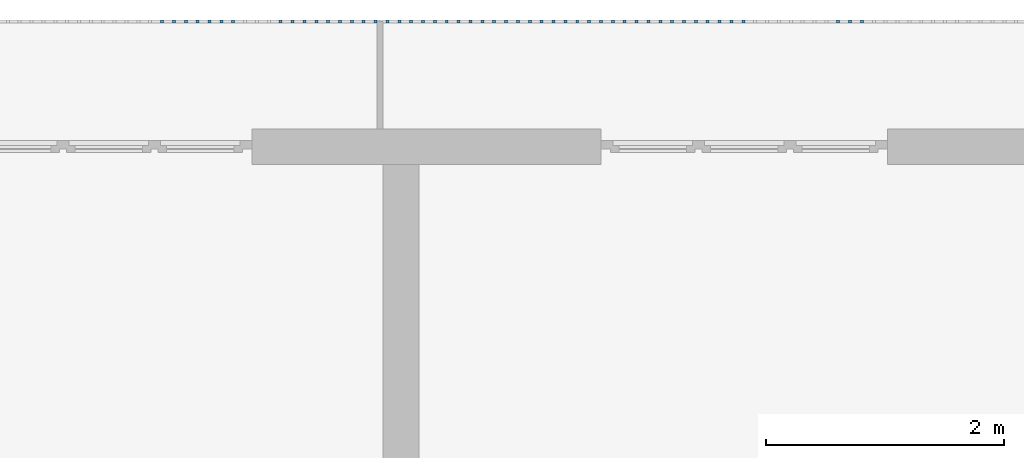
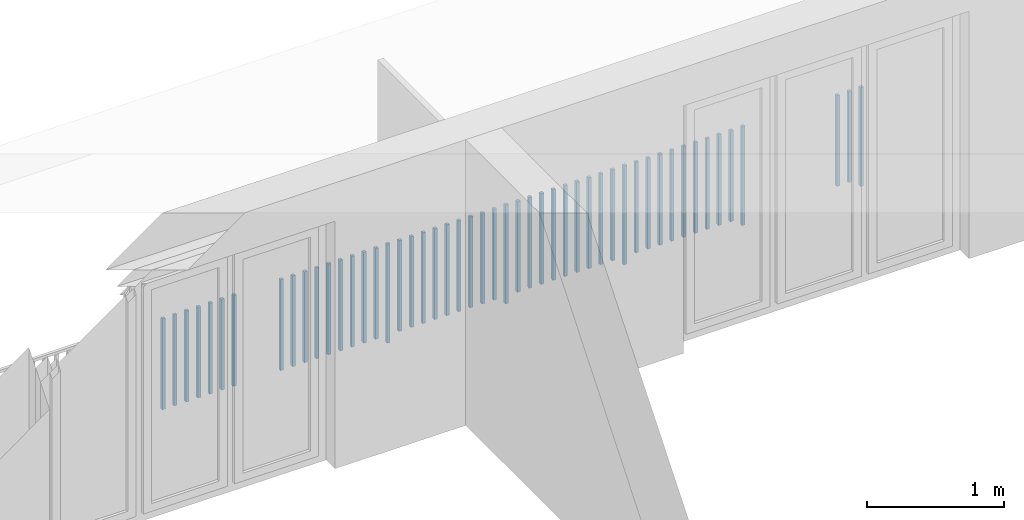
# One storey, part 44 of 48: 50 building element parts, 1 element without a shape of its own.
"""IFC4 building model written with IfcOpenShell, lengths in metres."""

import ifcopenshell
import ifcopenshell.guid

model = None  # the IFC model being written
_history = None  # IfcOwnerHistory: only IFC2X3 demands one
_inside = {}  # id of a spatial element -> (the spatial element, [elements in it])
_under = {}  # id of a project, library or spatial element -> (it, [spatial elements below it])
_declared = {}  # id of a project -> (the project, [libraries it declares])
_typed = {}  # id of a type object -> (the type object, [elements of that type])
_made_of = {}  # id of a material, layer set ... -> (it, [elements and type objects made of it])


def new_model(schema):
    """Start an empty IFC model of exactly this schema.

    Asked for "IFC4X3", IfcOpenShell would pick the latest addendum, in which some entities
    have other attributes; the version numbers below select the first issue.
    IFC2X3 requires an IfcOwnerHistory on every rooted entity: one is made here for all.
    """
    global model, _history
    if schema == "IFC4X3":
        model = ifcopenshell.file(schema_version=(4, 3, 0, 0))
    else:
        model = ifcopenshell.file(schema=schema)
    _inside.clear()
    _under.clear()
    _declared.clear()
    _typed.clear()
    _made_of.clear()
    _history = None
    if model.schema == "IFC2X3":
        org = make("IfcOrganization", Name="unknown")
        user = make(
            "IfcPersonAndOrganization",
            ThePerson=make("IfcPerson", FamilyName="unknown"),
            TheOrganization=org,
        )
        app = make(
            "IfcApplication",
            ApplicationDeveloper=org,
            Version="unknown",
            ApplicationFullName="unknown",
            ApplicationIdentifier="unknown",
        )
        _history = make(
            "IfcOwnerHistory",
            OwningUser=user,
            OwningApplication=app,
            ChangeAction="ADDED",
            CreationDate=0,
        )
    return model


def make(cls, **values):
    """One entity of the class cls with the attributes given. An attribute that is None is left unset."""
    return model.create_entity(
        cls, **{name: value for name, value in values.items() if value is not None}
    )


def entity(cls, *values):
    """Any entity or typed value of the class cls, its attributes in the order of the schema. None: left unset."""
    e = model.create_entity(cls)
    for i, value in enumerate(values):
        if value is not None:
            e[i] = value
    return e


def rooted(cls, **values):
    """An entity with a GlobalId (a new one), such as an element, a storey or a relation."""
    return make(cls, GlobalId=ifcopenshell.guid.new(), OwnerHistory=_history, **values)


def si_unit(unit_type, name, prefix=None):
    """IfcSIUnit, for example si_unit("LENGTHUNIT", "METRE", prefix="MILLI")."""
    return make("IfcSIUnit", UnitType=unit_type, Prefix=prefix, Name=name)


def converted_unit(unit_type, name, factor, base, dimensions=None, offset=None):
    """IfcConversionBasedUnit, such as the inch: factor (a typed value) times the base unit."""
    return make(
        "IfcConversionBasedUnit"
        if offset is None
        else "IfcConversionBasedUnitWithOffset",
        ConversionOffset=offset,
        Dimensions=None
        if dimensions is None
        else entity("IfcDimensionalExponents", *dimensions),
        UnitType=unit_type,
        Name=name,
        ConversionFactor=make(
            "IfcMeasureWithUnit", ValueComponent=factor, UnitComponent=base
        ),
    )


def derived_unit(unit_type, elements):
    """IfcDerivedUnit: a product of units, each with its exponent."""
    return make(
        "IfcDerivedUnit",
        Elements=[
            make("IfcDerivedUnitElement", Unit=unit, Exponent=power)
            for unit, power in elements
        ],
        UnitType=unit_type,
    )


def assignment(units):
    """IfcUnitAssignment: the units of a project."""
    return None if units is None else make("IfcUnitAssignment", Units=units)


def point(xyz):
    """IfcCartesianPoint."""
    return None if xyz is None else make("IfcCartesianPoint", Coordinates=xyz)


def direction(xyz):
    """IfcDirection."""
    return None if xyz is None else make("IfcDirection", DirectionRatios=xyz)


def frame(location, z_axis=None, x_axis=None):
    """IfcAxis2Placement3D, a coordinate frame: its origin and axes. An axis left out is left unset."""
    return make(
        "IfcAxis2Placement3D",
        Location=point(location),
        Axis=direction(z_axis),
        RefDirection=direction(x_axis),
    )


def origin_with_axes():
    """The frame at (0, 0, 0) with the z axis (0, 0, 1) and the x axis (1, 0, 0) written out."""
    return frame((0.0, 0.0, 0.0), z_axis=(0.0, 0.0, 1.0), x_axis=(1.0, 0.0, 0.0))


def place(relative_to, where):
    """IfcLocalPlacement: puts the frame where relative to a parent placement (None: the world)."""
    return make(
        "IfcLocalPlacement", PlacementRelTo=relative_to, RelativePlacement=where
    )


def context(
    kind, dimensions, precision=None, world=None, true_north=None, identifier=None
):
    """IfcGeometricRepresentationContext, for example the 3D "Model" context."""
    return make(
        "IfcGeometricRepresentationContext",
        ContextIdentifier=identifier,
        ContextType=kind,
        CoordinateSpaceDimension=dimensions,
        Precision=precision,
        WorldCoordinateSystem=world,
        TrueNorth=true_north,
    )


def subcontext(parent, identifier, kind, view, scale=None):
    """IfcGeometricRepresentationSubContext, for example "Body" below "Model"."""
    return make(
        "IfcGeometricRepresentationSubContext",
        ContextIdentifier=identifier,
        ContextType=kind,
        ParentContext=parent,
        TargetScale=scale,
        TargetView=view,
    )


def project(units=None, contexts=None):
    """IfcProject with its units and contexts."""
    return rooted(
        "IfcProject",
        Name="project",
        RepresentationContexts=contexts,
        UnitsInContext=assignment(units),
    )


def spatial(cls, under=None, at=None, **own):
    """A site, building, storey or space (cls), placed at a placement, below another one or the project."""
    s = rooted(cls, ObjectPlacement=at, **own)
    if under is not None:
        _under.setdefault(under.id(), (under, []))[1].append(s)
    return s


def point_list(points):
    """IfcCartesianPointList2D or 3D."""
    cls = (
        "IfcCartesianPointList2D" if len(points[0]) == 2 else "IfcCartesianPointList3D"
    )
    return make(cls, CoordList=points)


def polygons(points, faces, closed=None, point_numbers=None):
    """IfcPolygonalFaceSet: a face is its outer loop, then its inner loops; points numbered from 1."""
    made = []
    for loops in faces:
        if len(loops) == 1:
            made.append(make("IfcIndexedPolygonalFace", CoordIndex=loops[0]))
        else:
            made.append(
                make(
                    "IfcIndexedPolygonalFaceWithVoids",
                    CoordIndex=loops[0],
                    InnerCoordIndices=loops[1:],
                )
            )
    return make(
        "IfcPolygonalFaceSet",
        Coordinates=point_list(points),
        Closed=closed,
        Faces=made,
        PnIndex=point_numbers,
    )


def shape(context_of_items, identifier, shape_type, items):
    """IfcShapeRepresentation: the items that make up one representation, for example the "Body"."""
    return make(
        "IfcShapeRepresentation",
        ContextOfItems=context_of_items,
        RepresentationIdentifier=identifier,
        RepresentationType=shape_type,
        Items=items,
    )


def material(Name=None, Category=None):
    """IfcMaterial."""
    return make("IfcMaterial", Name=Name, Category=Category)


def made_of(thing, what):
    """Note that an element or type object is made of a material, layer set ...; save() writes the relation."""
    if what is not None:
        _made_of.setdefault(what.id(), (what, []))[1].append(thing)
    return thing


def type_object(cls, material=None, **own):
    """A type object (cls), such as IfcWallType, which elements share."""
    return made_of(rooted(cls, **own), material)


def element(
    cls,
    number,
    at=None,
    inside=None,
    cuts=None,
    type_object=None,
    material=None,
    context=None,
    identifier="Body",
    shape_type=None,
    held_by="IfcProductDefinitionShape",
    body=None,
    shapes=None,
    **own,
):
    """One element of the class cls, such as IfcWall. Its Tag is "e" and its number.

    at: its placement. inside: the storey or other place that contains it. cuts: it is an
    opening in that element (IfcRelVoidsElement). A single representation is given by context,
    identifier, shape_type and body (its items); several are given by shapes. held_by: the class
    of the entity that holds the representations. save() writes the other relations.
    """
    e = rooted(cls, Tag="e%d" % number, ObjectPlacement=at, **own)
    if body is not None:
        shapes = [shape(context, identifier, shape_type, body)]
    if shapes is not None:
        e.Representation = make(held_by, Representations=shapes)
    if inside is not None:
        _inside.setdefault(inside.id(), (inside, []))[1].append(e)
    if cuts is not None:
        rooted(
            "IfcRelVoidsElement", RelatingBuildingElement=cuts, RelatedOpeningElement=e
        )
    if type_object is not None:
        _typed.setdefault(type_object.id(), (type_object, []))[1].append(e)
    return made_of(e, material)


def aggregate(whole, parts):
    """IfcRelAggregates: a whole, such as a stair, and the parts it consists of."""
    return rooted("IfcRelAggregates", RelatingObject=whole, RelatedObjects=parts)


def save(model, path):
    """Write the relations noted so far, then the file.

    IfcRelAggregates (storeys below a building ...), IfcRelContainedInSpatialStructure (elements
    in a storey), IfcRelDefinesByType, IfcRelAssociatesMaterial and IfcRelDeclares: one each for
    every whole, place, type object, material and project.
    """
    for whole, parts in _under.values():
        aggregate(whole, parts)
    for where, things in _inside.values():
        rooted(
            "IfcRelContainedInSpatialStructure",
            RelatedElements=things,
            RelatingStructure=where,
        )
    for kind, things in _typed.values():
        rooted("IfcRelDefinesByType", RelatedObjects=things, RelatingType=kind)
    for what, things in _made_of.values():
        rooted("IfcRelAssociatesMaterial", RelatedObjects=things, RelatingMaterial=what)
    for by, libraries in _declared.values():
        rooted("IfcRelDeclares", RelatingContext=by, RelatedDefinitions=libraries)
    model.write(path)


model = new_model("IFC4")

# Units and contexts
model_context = context("Model", 3, precision=1e-05, world=origin_with_axes(), true_north=direction((0.0, 1.0)))
body_context = subcontext(model_context, "Body", "Model", "MODEL_VIEW")
ifc_project = project(units=[si_unit("LENGTHUNIT", "METRE"), si_unit("AREAUNIT", "SQUARE_METRE"), si_unit("VOLUMEUNIT", "CUBIC_METRE"), converted_unit("PLANEANGLEUNIT", "DEGREE", entity("IfcPlaneAngleMeasure", 0.0174532925199), si_unit("PLANEANGLEUNIT", "RADIAN"), dimensions=[0, 0, 0, 0, 0, 0, 0]), converted_unit("TIMEUNIT", "Year", entity("IfcTimeMeasure", 31556926.0), si_unit("TIMEUNIT", "SECOND"), dimensions=[0, 0, 1, 0, 0, 0, 0]), si_unit("MASSUNIT", "GRAM", prefix="KILO"), si_unit("THERMODYNAMICTEMPERATUREUNIT", "DEGREE_CELSIUS"), si_unit("LUMINOUSINTENSITYUNIT", "LUMEN"), si_unit("ENERGYUNIT", "JOULE", prefix="MEGA"), derived_unit("THERMALCONDUCTANCEUNIT", [(si_unit("POWERUNIT", "WATT"), 1), (si_unit("LENGTHUNIT", "METRE"), -1), (si_unit("THERMODYNAMICTEMPERATUREUNIT", "KELVIN"), -1)]), derived_unit("SPECIFICHEATCAPACITYUNIT", [(si_unit("ENERGYUNIT", "JOULE"), 1), (si_unit("MASSUNIT", "GRAM", prefix="KILO"), -1), (si_unit("THERMODYNAMICTEMPERATUREUNIT", "KELVIN"), -1)]), derived_unit("MASSDENSITYUNIT", [(si_unit("MASSUNIT", "GRAM", prefix="KILO"), 1), (si_unit("VOLUMEUNIT", "CUBIC_METRE"), -1)])], contexts=[model_context])

# Site, building, storey
site_placement = place(None, origin_with_axes())
site = spatial("IfcSite", under=ifc_project, at=site_placement, CompositionType="ELEMENT")
building_placement = place(site_placement, origin_with_axes())
building = spatial("IfcBuilding", under=site, at=building_placement, CompositionType="ELEMENT")
storey_placement = place(building_placement, frame((0.0, 0.0, 3.4), z_axis=(0.0, 0.0, 1.0), x_axis=(1.0, 0.0, 0.0)))
storey = spatial("IfcBuildingStorey", under=building, at=storey_placement, Name="1. Geschoss", CompositionType="ELEMENT", Elevation=3.4)

# Railing, building element parts
railing_type = type_object("IfcRailingType", PredefinedType="NOTDEFINED")
railing_placement = place(storey_placement, frame((10.2378006196, 9.82118776896, 0.0), z_axis=(0.0, 0.0, 1.0), x_axis=(1.0, 0.0, 0.0)))
railing = element("IfcRailing", 1, at=railing_placement, inside=storey, type_object=railing_type, PredefinedType="NOTDEFINED")
ifc_material = material()
building_element_part_1_placement = place(railing_placement, origin_with_axes())
building_element_part_1 = element("IfcBuildingElementPart", 2, at=building_element_part_1_placement, material=ifc_material, PredefinedType="NOTDEFINED", context=body_context, shape_type="Tessellation", body=[
    polygons([(-6.97597826087, 0.0125, 0.0), (-6.97597826087, -0.0125, 0.0), (-6.97597826087, -0.0125, 0.88), (-6.97597826087, 0.0125, 0.88), (-6.95097826087, 0.0125, 0.0), (-6.95097826087, -0.0125, 0.0), (-6.95097826087, -0.0125, 0.88), (-6.95097826087, 0.0125, 0.88)], [[[1, 2, 3, 4]], [[1, 5, 6, 2]], [[2, 6, 7, 3]], [[4, 3, 7, 8]], [[5, 1, 4, 8]], [[6, 5, 8, 7]]], closed=True),
])
building_element_part_2_placement = place(railing_placement, origin_with_axes())
building_element_part_2 = element("IfcBuildingElementPart", 3, at=building_element_part_2_placement, material=ifc_material, PredefinedType="NOTDEFINED", context=body_context, shape_type="Tessellation", body=[
    polygons([(-7.07545652174, 0.0125, 0.07), (-7.07545652174, -0.0125, 0.07), (-7.07545652174, -0.0125, 0.8775), (-7.07545652174, 0.0125, 0.8775), (-7.05045652174, 0.0125, 0.07), (-7.05045652174, -0.0125, 0.07), (-7.05045652174, -0.0125, 0.8775), (-7.05045652174, 0.0125, 0.8775)], [[[1, 2, 3, 4]], [[1, 5, 6, 2]], [[2, 6, 7, 3]], [[4, 3, 7, 8]], [[5, 1, 4, 8]], [[6, 5, 8, 7]]], closed=True),
])
building_element_part_3_placement = place(railing_placement, origin_with_axes())
building_element_part_3 = element("IfcBuildingElementPart", 4, at=building_element_part_3_placement, material=ifc_material, PredefinedType="NOTDEFINED", context=body_context, shape_type="Tessellation", body=[
    polygons([(-7.17493478261, 0.0125, 0.07), (-7.17493478261, -0.0125, 0.07), (-7.17493478261, -0.0125, 0.8775), (-7.17493478261, 0.0125, 0.8775), (-7.14993478261, 0.0125, 0.07), (-7.14993478261, -0.0125, 0.07), (-7.14993478261, -0.0125, 0.8775), (-7.14993478261, 0.0125, 0.8775)], [[[1, 2, 3, 4]], [[1, 5, 6, 2]], [[2, 6, 7, 3]], [[4, 3, 7, 8]], [[5, 1, 4, 8]], [[6, 5, 8, 7]]], closed=True),
])
building_element_part_4_placement = place(railing_placement, origin_with_axes())
building_element_part_4 = element("IfcBuildingElementPart", 5, at=building_element_part_4_placement, material=ifc_material, PredefinedType="NOTDEFINED", context=body_context, shape_type="Tessellation", body=[
    polygons([(-7.97076086957, 0.0125, 0.0), (-7.97076086957, -0.0125, 0.0), (-7.97076086957, -0.0125, 0.88), (-7.97076086957, 0.0125, 0.88), (-7.94576086957, 0.0125, 0.0), (-7.94576086957, -0.0125, 0.0), (-7.94576086957, -0.0125, 0.88), (-7.94576086957, 0.0125, 0.88)], [[[1, 2, 3, 4]], [[1, 5, 6, 2]], [[2, 6, 7, 3]], [[4, 3, 7, 8]], [[5, 1, 4, 8]], [[6, 5, 8, 7]]], closed=True),
])
building_element_part_5_placement = place(railing_placement, origin_with_axes())
building_element_part_5 = element("IfcBuildingElementPart", 6, at=building_element_part_5_placement, material=ifc_material, PredefinedType="NOTDEFINED", context=body_context, shape_type="Tessellation", body=[
    polygons([(-8.07023913043, 0.0125, 0.07), (-8.07023913043, -0.0125, 0.07), (-8.07023913043, -0.0125, 0.8775), (-8.07023913043, 0.0125, 0.8775), (-8.04523913043, 0.0125, 0.07), (-8.04523913043, -0.0125, 0.07), (-8.04523913043, -0.0125, 0.8775), (-8.04523913043, 0.0125, 0.8775)], [[[1, 2, 3, 4]], [[1, 5, 6, 2]], [[2, 6, 7, 3]], [[4, 3, 7, 8]], [[5, 1, 4, 8]], [[6, 5, 8, 7]]], closed=True),
])
building_element_part_6_placement = place(railing_placement, origin_with_axes())
building_element_part_6 = element("IfcBuildingElementPart", 7, at=building_element_part_6_placement, material=ifc_material, PredefinedType="NOTDEFINED", context=body_context, shape_type="Tessellation", body=[
    polygons([(-8.1697173913, 0.0125, 0.07), (-8.1697173913, -0.0125, 0.07), (-8.1697173913, -0.0125, 0.8775), (-8.1697173913, 0.0125, 0.8775), (-8.1447173913, 0.0125, 0.07), (-8.1447173913, -0.0125, 0.07), (-8.1447173913, -0.0125, 0.8775), (-8.1447173913, 0.0125, 0.8775)], [[[1, 2, 3, 4]], [[1, 5, 6, 2]], [[2, 6, 7, 3]], [[4, 3, 7, 8]], [[5, 1, 4, 8]], [[6, 5, 8, 7]]], closed=True),
])
building_element_part_7_placement = place(railing_placement, origin_with_axes())
building_element_part_7 = element("IfcBuildingElementPart", 8, at=building_element_part_7_placement, material=ifc_material, PredefinedType="NOTDEFINED", context=body_context, shape_type="Tessellation", body=[
    polygons([(-8.26919565217, 0.0125, 0.07), (-8.26919565217, -0.0125, 0.07), (-8.26919565217, -0.0125, 0.8775), (-8.26919565217, 0.0125, 0.8775), (-8.24419565217, 0.0125, 0.07), (-8.24419565217, -0.0125, 0.07), (-8.24419565217, -0.0125, 0.8775), (-8.24419565217, 0.0125, 0.8775)], [[[1, 2, 3, 4]], [[1, 5, 6, 2]], [[2, 6, 7, 3]], [[4, 3, 7, 8]], [[5, 1, 4, 8]], [[6, 5, 8, 7]]], closed=True),
])
building_element_part_8_placement = place(railing_placement, origin_with_axes())
building_element_part_8 = element("IfcBuildingElementPart", 9, at=building_element_part_8_placement, material=ifc_material, PredefinedType="NOTDEFINED", context=body_context, shape_type="Tessellation", body=[
    polygons([(-8.36867391304, 0.0125, 0.07), (-8.36867391304, -0.0125, 0.07), (-8.36867391304, -0.0125, 0.8775), (-8.36867391304, 0.0125, 0.8775), (-8.34367391304, 0.0125, 0.07), (-8.34367391304, -0.0125, 0.07), (-8.34367391304, -0.0125, 0.8775), (-8.34367391304, 0.0125, 0.8775)], [[[1, 2, 3, 4]], [[1, 5, 6, 2]], [[2, 6, 7, 3]], [[4, 3, 7, 8]], [[5, 1, 4, 8]], [[6, 5, 8, 7]]], closed=True),
])
building_element_part_9_placement = place(railing_placement, origin_with_axes())
building_element_part_9 = element("IfcBuildingElementPart", 10, at=building_element_part_9_placement, material=ifc_material, PredefinedType="NOTDEFINED", context=body_context, shape_type="Tessellation", body=[
    polygons([(-8.46815217391, 0.0125, 0.07), (-8.46815217391, -0.0125, 0.07), (-8.46815217391, -0.0125, 0.8775), (-8.46815217391, 0.0125, 0.8775), (-8.44315217391, 0.0125, 0.07), (-8.44315217391, -0.0125, 0.07), (-8.44315217391, -0.0125, 0.8775), (-8.44315217391, 0.0125, 0.8775)], [[[1, 2, 3, 4]], [[1, 5, 6, 2]], [[2, 6, 7, 3]], [[4, 3, 7, 8]], [[5, 1, 4, 8]], [[6, 5, 8, 7]]], closed=True),
])
building_element_part_10_placement = place(railing_placement, origin_with_axes())
building_element_part_10 = element("IfcBuildingElementPart", 11, at=building_element_part_10_placement, material=ifc_material, PredefinedType="NOTDEFINED", context=body_context, shape_type="Tessellation", body=[
    polygons([(-8.56763043478, 0.0125, 0.07), (-8.56763043478, -0.0125, 0.07), (-8.56763043478, -0.0125, 0.8775), (-8.56763043478, 0.0125, 0.8775), (-8.54263043478, 0.0125, 0.07), (-8.54263043478, -0.0125, 0.07), (-8.54263043478, -0.0125, 0.8775), (-8.54263043478, 0.0125, 0.8775)], [[[1, 2, 3, 4]], [[1, 5, 6, 2]], [[2, 6, 7, 3]], [[4, 3, 7, 8]], [[5, 1, 4, 8]], [[6, 5, 8, 7]]], closed=True),
])
building_element_part_11_placement = place(railing_placement, origin_with_axes())
building_element_part_11 = element("IfcBuildingElementPart", 12, at=building_element_part_11_placement, material=ifc_material, PredefinedType="NOTDEFINED", context=body_context, shape_type="Tessellation", body=[
    polygons([(-8.66710869565, 0.0125, 0.07), (-8.66710869565, -0.0125, 0.07), (-8.66710869565, -0.0125, 0.8775), (-8.66710869565, 0.0125, 0.8775), (-8.64210869565, 0.0125, 0.07), (-8.64210869565, -0.0125, 0.07), (-8.64210869565, -0.0125, 0.8775), (-8.64210869565, 0.0125, 0.8775)], [[[1, 2, 3, 4]], [[1, 5, 6, 2]], [[2, 6, 7, 3]], [[4, 3, 7, 8]], [[5, 1, 4, 8]], [[6, 5, 8, 7]]], closed=True),
])
building_element_part_12_placement = place(railing_placement, origin_with_axes())
building_element_part_12 = element("IfcBuildingElementPart", 13, at=building_element_part_12_placement, material=ifc_material, PredefinedType="NOTDEFINED", context=body_context, shape_type="Tessellation", body=[
    polygons([(-8.76658695652, 0.0125, 0.07), (-8.76658695652, -0.0125, 0.07), (-8.76658695652, -0.0125, 0.8775), (-8.76658695652, 0.0125, 0.8775), (-8.74158695652, 0.0125, 0.07), (-8.74158695652, -0.0125, 0.07), (-8.74158695652, -0.0125, 0.8775), (-8.74158695652, 0.0125, 0.8775)], [[[1, 2, 3, 4]], [[1, 5, 6, 2]], [[2, 6, 7, 3]], [[4, 3, 7, 8]], [[5, 1, 4, 8]], [[6, 5, 8, 7]]], closed=True),
])
building_element_part_13_placement = place(railing_placement, origin_with_axes())
building_element_part_13 = element("IfcBuildingElementPart", 14, at=building_element_part_13_placement, material=ifc_material, PredefinedType="NOTDEFINED", context=body_context, shape_type="Tessellation", body=[
    polygons([(-8.86606521739, 0.0125, 0.07), (-8.86606521739, -0.0125, 0.07), (-8.86606521739, -0.0125, 0.8775), (-8.86606521739, 0.0125, 0.8775), (-8.84106521739, 0.0125, 0.07), (-8.84106521739, -0.0125, 0.07), (-8.84106521739, -0.0125, 0.8775), (-8.84106521739, 0.0125, 0.8775)], [[[1, 2, 3, 4]], [[1, 5, 6, 2]], [[2, 6, 7, 3]], [[4, 3, 7, 8]], [[5, 1, 4, 8]], [[6, 5, 8, 7]]], closed=True),
])
building_element_part_14_placement = place(railing_placement, origin_with_axes())
building_element_part_14 = element("IfcBuildingElementPart", 15, at=building_element_part_14_placement, material=ifc_material, PredefinedType="NOTDEFINED", context=body_context, shape_type="Tessellation", body=[
    polygons([(-8.96554347826, 0.0125, 0.0), (-8.96554347826, -0.0125, 0.0), (-8.96554347826, -0.0125, 0.88), (-8.96554347826, 0.0125, 0.88), (-8.94054347826, 0.0125, 0.0), (-8.94054347826, -0.0125, 0.0), (-8.94054347826, -0.0125, 0.88), (-8.94054347826, 0.0125, 0.88)], [[[1, 2, 3, 4]], [[1, 5, 6, 2]], [[2, 6, 7, 3]], [[4, 3, 7, 8]], [[5, 1, 4, 8]], [[6, 5, 8, 7]]], closed=True),
])
building_element_part_15_placement = place(railing_placement, origin_with_axes())
building_element_part_15 = element("IfcBuildingElementPart", 16, at=building_element_part_15_placement, material=ifc_material, PredefinedType="NOTDEFINED", context=body_context, shape_type="Tessellation", body=[
    polygons([(-9.06502173913, 0.0125, 0.07), (-9.06502173913, -0.0125, 0.07), (-9.06502173913, -0.0125, 0.8775), (-9.06502173913, 0.0125, 0.8775), (-9.04002173913, 0.0125, 0.07), (-9.04002173913, -0.0125, 0.07), (-9.04002173913, -0.0125, 0.8775), (-9.04002173913, 0.0125, 0.8775)], [[[1, 2, 3, 4]], [[1, 5, 6, 2]], [[2, 6, 7, 3]], [[4, 3, 7, 8]], [[5, 1, 4, 8]], [[6, 5, 8, 7]]], closed=True),
])
building_element_part_16_placement = place(railing_placement, origin_with_axes())
building_element_part_16 = element("IfcBuildingElementPart", 17, at=building_element_part_16_placement, material=ifc_material, PredefinedType="NOTDEFINED", context=body_context, shape_type="Tessellation", body=[
    polygons([(-9.1645, 0.0125, 0.07), (-9.1645, -0.0125, 0.07), (-9.1645, -0.0125, 0.8775), (-9.1645, 0.0125, 0.8775), (-9.1395, 0.0125, 0.07), (-9.1395, -0.0125, 0.07), (-9.1395, -0.0125, 0.8775), (-9.1395, 0.0125, 0.8775)], [[[1, 2, 3, 4]], [[1, 5, 6, 2]], [[2, 6, 7, 3]], [[4, 3, 7, 8]], [[5, 1, 4, 8]], [[6, 5, 8, 7]]], closed=True),
])
building_element_part_17_placement = place(railing_placement, origin_with_axes())
building_element_part_17 = element("IfcBuildingElementPart", 18, at=building_element_part_17_placement, material=ifc_material, PredefinedType="NOTDEFINED", context=body_context, shape_type="Tessellation", body=[
    polygons([(-9.26397826087, 0.0125, 0.07), (-9.26397826087, -0.0125, 0.07), (-9.26397826087, -0.0125, 0.8775), (-9.26397826087, 0.0125, 0.8775), (-9.23897826087, 0.0125, 0.07), (-9.23897826087, -0.0125, 0.07), (-9.23897826087, -0.0125, 0.8775), (-9.23897826087, 0.0125, 0.8775)], [[[1, 2, 3, 4]], [[1, 5, 6, 2]], [[2, 6, 7, 3]], [[4, 3, 7, 8]], [[5, 1, 4, 8]], [[6, 5, 8, 7]]], closed=True),
])
building_element_part_18_placement = place(railing_placement, origin_with_axes())
building_element_part_18 = element("IfcBuildingElementPart", 19, at=building_element_part_18_placement, material=ifc_material, PredefinedType="NOTDEFINED", context=body_context, shape_type="Tessellation", body=[
    polygons([(-9.36345652174, 0.0125, 0.07), (-9.36345652174, -0.0125, 0.07), (-9.36345652174, -0.0125, 0.8775), (-9.36345652174, 0.0125, 0.8775), (-9.33845652174, 0.0125, 0.07), (-9.33845652174, -0.0125, 0.07), (-9.33845652174, -0.0125, 0.8775), (-9.33845652174, 0.0125, 0.8775)], [[[1, 2, 3, 4]], [[1, 5, 6, 2]], [[2, 6, 7, 3]], [[4, 3, 7, 8]], [[5, 1, 4, 8]], [[6, 5, 8, 7]]], closed=True),
])
building_element_part_19_placement = place(railing_placement, origin_with_axes())
building_element_part_19 = element("IfcBuildingElementPart", 20, at=building_element_part_19_placement, material=ifc_material, PredefinedType="NOTDEFINED", context=body_context, shape_type="Tessellation", body=[
    polygons([(-9.46293478261, 0.0125, 0.07), (-9.46293478261, -0.0125, 0.07), (-9.46293478261, -0.0125, 0.8775), (-9.46293478261, 0.0125, 0.8775), (-9.43793478261, 0.0125, 0.07), (-9.43793478261, -0.0125, 0.07), (-9.43793478261, -0.0125, 0.8775), (-9.43793478261, 0.0125, 0.8775)], [[[1, 2, 3, 4]], [[1, 5, 6, 2]], [[2, 6, 7, 3]], [[4, 3, 7, 8]], [[5, 1, 4, 8]], [[6, 5, 8, 7]]], closed=True),
])
building_element_part_20_placement = place(railing_placement, origin_with_axes())
building_element_part_20 = element("IfcBuildingElementPart", 21, at=building_element_part_20_placement, material=ifc_material, PredefinedType="NOTDEFINED", context=body_context, shape_type="Tessellation", body=[
    polygons([(-9.56241304348, 0.0125, 0.07), (-9.56241304348, -0.0125, 0.07), (-9.56241304348, -0.0125, 0.8775), (-9.56241304348, 0.0125, 0.8775), (-9.53741304348, 0.0125, 0.07), (-9.53741304348, -0.0125, 0.07), (-9.53741304348, -0.0125, 0.8775), (-9.53741304348, 0.0125, 0.8775)], [[[1, 2, 3, 4]], [[1, 5, 6, 2]], [[2, 6, 7, 3]], [[4, 3, 7, 8]], [[5, 1, 4, 8]], [[6, 5, 8, 7]]], closed=True),
])
building_element_part_21_placement = place(railing_placement, origin_with_axes())
building_element_part_21 = element("IfcBuildingElementPart", 22, at=building_element_part_21_placement, material=ifc_material, PredefinedType="NOTDEFINED", context=body_context, shape_type="Tessellation", body=[
    polygons([(-9.66189130435, 0.0125, 0.07), (-9.66189130435, -0.0125, 0.07), (-9.66189130435, -0.0125, 0.8775), (-9.66189130435, 0.0125, 0.8775), (-9.63689130435, 0.0125, 0.07), (-9.63689130435, -0.0125, 0.07), (-9.63689130435, -0.0125, 0.8775), (-9.63689130435, 0.0125, 0.8775)], [[[1, 2, 3, 4]], [[1, 5, 6, 2]], [[2, 6, 7, 3]], [[4, 3, 7, 8]], [[5, 1, 4, 8]], [[6, 5, 8, 7]]], closed=True),
])
building_element_part_22_placement = place(railing_placement, origin_with_axes())
building_element_part_22 = element("IfcBuildingElementPart", 23, at=building_element_part_22_placement, material=ifc_material, PredefinedType="NOTDEFINED", context=body_context, shape_type="Tessellation", body=[
    polygons([(-9.76136956522, 0.0125, 0.07), (-9.76136956522, -0.0125, 0.07), (-9.76136956522, -0.0125, 0.8775), (-9.76136956522, 0.0125, 0.8775), (-9.73636956522, 0.0125, 0.07), (-9.73636956522, -0.0125, 0.07), (-9.73636956522, -0.0125, 0.8775), (-9.73636956522, 0.0125, 0.8775)], [[[1, 2, 3, 4]], [[1, 5, 6, 2]], [[2, 6, 7, 3]], [[4, 3, 7, 8]], [[5, 1, 4, 8]], [[6, 5, 8, 7]]], closed=True),
])
building_element_part_23_placement = place(railing_placement, origin_with_axes())
building_element_part_23 = element("IfcBuildingElementPart", 24, at=building_element_part_23_placement, material=ifc_material, PredefinedType="NOTDEFINED", context=body_context, shape_type="Tessellation", body=[
    polygons([(-9.86084782609, 0.0125, 0.07), (-9.86084782609, -0.0125, 0.07), (-9.86084782609, -0.0125, 0.8775), (-9.86084782609, 0.0125, 0.8775), (-9.83584782609, 0.0125, 0.07), (-9.83584782609, -0.0125, 0.07), (-9.83584782609, -0.0125, 0.8775), (-9.83584782609, 0.0125, 0.8775)], [[[1, 2, 3, 4]], [[1, 5, 6, 2]], [[2, 6, 7, 3]], [[4, 3, 7, 8]], [[5, 1, 4, 8]], [[6, 5, 8, 7]]], closed=True),
])
building_element_part_24_placement = place(railing_placement, origin_with_axes())
building_element_part_24 = element("IfcBuildingElementPart", 25, at=building_element_part_24_placement, material=ifc_material, PredefinedType="NOTDEFINED", context=body_context, shape_type="Tessellation", body=[
    polygons([(-9.96032608696, 0.0125, 0.0), (-9.96032608696, -0.0125, 0.0), (-9.96032608696, -0.0125, 0.88), (-9.96032608696, 0.0125, 0.88), (-9.93532608696, 0.0125, 0.0), (-9.93532608696, -0.0125, 0.0), (-9.93532608696, -0.0125, 0.88), (-9.93532608696, 0.0125, 0.88)], [[[1, 2, 3, 4]], [[1, 5, 6, 2]], [[2, 6, 7, 3]], [[4, 3, 7, 8]], [[5, 1, 4, 8]], [[6, 5, 8, 7]]], closed=True),
])
building_element_part_25_placement = place(railing_placement, origin_with_axes())
building_element_part_25 = element("IfcBuildingElementPart", 26, at=building_element_part_25_placement, material=ifc_material, PredefinedType="NOTDEFINED", context=body_context, shape_type="Tessellation", body=[
    polygons([(-10.0598043478, 0.0125, 0.07), (-10.0598043478, -0.0125, 0.07), (-10.0598043478, -0.0125, 0.8775), (-10.0598043478, 0.0125, 0.8775), (-10.0348043478, 0.0125, 0.07), (-10.0348043478, -0.0125, 0.07), (-10.0348043478, -0.0125, 0.8775), (-10.0348043478, 0.0125, 0.8775)], [[[1, 2, 3, 4]], [[1, 5, 6, 2]], [[2, 6, 7, 3]], [[4, 3, 7, 8]], [[5, 1, 4, 8]], [[6, 5, 8, 7]]], closed=True),
])
building_element_part_26_placement = place(railing_placement, origin_with_axes())
building_element_part_26 = element("IfcBuildingElementPart", 27, at=building_element_part_26_placement, material=ifc_material, PredefinedType="NOTDEFINED", context=body_context, shape_type="Tessellation", body=[
    polygons([(-10.1592826087, 0.0125, 0.07), (-10.1592826087, -0.0125, 0.07), (-10.1592826087, -0.0125, 0.8775), (-10.1592826087, 0.0125, 0.8775), (-10.1342826087, 0.0125, 0.07), (-10.1342826087, -0.0125, 0.07), (-10.1342826087, -0.0125, 0.8775), (-10.1342826087, 0.0125, 0.8775)], [[[1, 2, 3, 4]], [[1, 5, 6, 2]], [[2, 6, 7, 3]], [[4, 3, 7, 8]], [[5, 1, 4, 8]], [[6, 5, 8, 7]]], closed=True),
])
building_element_part_27_placement = place(railing_placement, origin_with_axes())
building_element_part_27 = element("IfcBuildingElementPart", 28, at=building_element_part_27_placement, material=ifc_material, PredefinedType="NOTDEFINED", context=body_context, shape_type="Tessellation", body=[
    polygons([(-10.2587608696, 0.0125, 0.07), (-10.2587608696, -0.0125, 0.07), (-10.2587608696, -0.0125, 0.8775), (-10.2587608696, 0.0125, 0.8775), (-10.2337608696, 0.0125, 0.07), (-10.2337608696, -0.0125, 0.07), (-10.2337608696, -0.0125, 0.8775), (-10.2337608696, 0.0125, 0.8775)], [[[1, 2, 3, 4]], [[1, 5, 6, 2]], [[2, 6, 7, 3]], [[4, 3, 7, 8]], [[5, 1, 4, 8]], [[6, 5, 8, 7]]], closed=True),
])
building_element_part_28_placement = place(railing_placement, origin_with_axes())
building_element_part_28 = element("IfcBuildingElementPart", 29, at=building_element_part_28_placement, material=ifc_material, PredefinedType="NOTDEFINED", context=body_context, shape_type="Tessellation", body=[
    polygons([(-10.3582391304, 0.0125, 0.07), (-10.3582391304, -0.0125, 0.07), (-10.3582391304, -0.0125, 0.8775), (-10.3582391304, 0.0125, 0.8775), (-10.3332391304, 0.0125, 0.07), (-10.3332391304, -0.0125, 0.07), (-10.3332391304, -0.0125, 0.8775), (-10.3332391304, 0.0125, 0.8775)], [[[1, 2, 3, 4]], [[1, 5, 6, 2]], [[2, 6, 7, 3]], [[4, 3, 7, 8]], [[5, 1, 4, 8]], [[6, 5, 8, 7]]], closed=True),
])
building_element_part_29_placement = place(railing_placement, origin_with_axes())
building_element_part_29 = element("IfcBuildingElementPart", 30, at=building_element_part_29_placement, material=ifc_material, PredefinedType="NOTDEFINED", context=body_context, shape_type="Tessellation", body=[
    polygons([(-10.4577173913, 0.0125, 0.07), (-10.4577173913, -0.0125, 0.07), (-10.4577173913, -0.0125, 0.8775), (-10.4577173913, 0.0125, 0.8775), (-10.4327173913, 0.0125, 0.07), (-10.4327173913, -0.0125, 0.07), (-10.4327173913, -0.0125, 0.8775), (-10.4327173913, 0.0125, 0.8775)], [[[1, 2, 3, 4]], [[1, 5, 6, 2]], [[2, 6, 7, 3]], [[4, 3, 7, 8]], [[5, 1, 4, 8]], [[6, 5, 8, 7]]], closed=True),
])
building_element_part_30_placement = place(railing_placement, origin_with_axes())
building_element_part_30 = element("IfcBuildingElementPart", 31, at=building_element_part_30_placement, material=ifc_material, PredefinedType="NOTDEFINED", context=body_context, shape_type="Tessellation", body=[
    polygons([(-10.5571956522, 0.0125, 0.07), (-10.5571956522, -0.0125, 0.07), (-10.5571956522, -0.0125, 0.8775), (-10.5571956522, 0.0125, 0.8775), (-10.5321956522, 0.0125, 0.07), (-10.5321956522, -0.0125, 0.07), (-10.5321956522, -0.0125, 0.8775), (-10.5321956522, 0.0125, 0.8775)], [[[1, 2, 3, 4]], [[1, 5, 6, 2]], [[2, 6, 7, 3]], [[4, 3, 7, 8]], [[5, 1, 4, 8]], [[6, 5, 8, 7]]], closed=True),
])
building_element_part_31_placement = place(railing_placement, origin_with_axes())
building_element_part_31 = element("IfcBuildingElementPart", 32, at=building_element_part_31_placement, material=ifc_material, PredefinedType="NOTDEFINED", context=body_context, shape_type="Tessellation", body=[
    polygons([(-10.656673913, 0.0125, 0.07), (-10.656673913, -0.0125, 0.07), (-10.656673913, -0.0125, 0.8775), (-10.656673913, 0.0125, 0.8775), (-10.631673913, 0.0125, 0.07), (-10.631673913, -0.0125, 0.07), (-10.631673913, -0.0125, 0.8775), (-10.631673913, 0.0125, 0.8775)], [[[1, 2, 3, 4]], [[1, 5, 6, 2]], [[2, 6, 7, 3]], [[4, 3, 7, 8]], [[5, 1, 4, 8]], [[6, 5, 8, 7]]], closed=True),
])
building_element_part_32_placement = place(railing_placement, origin_with_axes())
building_element_part_32 = element("IfcBuildingElementPart", 33, at=building_element_part_32_placement, material=ifc_material, PredefinedType="NOTDEFINED", context=body_context, shape_type="Tessellation", body=[
    polygons([(-10.7561521739, 0.0125, 0.07), (-10.7561521739, -0.0125, 0.07), (-10.7561521739, -0.0125, 0.8775), (-10.7561521739, 0.0125, 0.8775), (-10.7311521739, 0.0125, 0.07), (-10.7311521739, -0.0125, 0.07), (-10.7311521739, -0.0125, 0.8775), (-10.7311521739, 0.0125, 0.8775)], [[[1, 2, 3, 4]], [[1, 5, 6, 2]], [[2, 6, 7, 3]], [[4, 3, 7, 8]], [[5, 1, 4, 8]], [[6, 5, 8, 7]]], closed=True),
])
building_element_part_33_placement = place(railing_placement, origin_with_axes())
building_element_part_33 = element("IfcBuildingElementPart", 34, at=building_element_part_33_placement, material=ifc_material, PredefinedType="NOTDEFINED", context=body_context, shape_type="Tessellation", body=[
    polygons([(-10.8556304348, 0.0125, 0.07), (-10.8556304348, -0.0125, 0.07), (-10.8556304348, -0.0125, 0.8775), (-10.8556304348, 0.0125, 0.8775), (-10.8306304348, 0.0125, 0.07), (-10.8306304348, -0.0125, 0.07), (-10.8306304348, -0.0125, 0.8775), (-10.8306304348, 0.0125, 0.8775)], [[[1, 2, 3, 4]], [[1, 5, 6, 2]], [[2, 6, 7, 3]], [[4, 3, 7, 8]], [[5, 1, 4, 8]], [[6, 5, 8, 7]]], closed=True),
])
building_element_part_34_placement = place(railing_placement, origin_with_axes())
building_element_part_34 = element("IfcBuildingElementPart", 35, at=building_element_part_34_placement, material=ifc_material, PredefinedType="NOTDEFINED", context=body_context, shape_type="Tessellation", body=[
    polygons([(-10.9551086957, 0.0125, 0.0), (-10.9551086957, -0.0125, 0.0), (-10.9551086957, -0.0125, 0.88), (-10.9551086957, 0.0125, 0.88), (-10.9301086957, 0.0125, 0.0), (-10.9301086957, -0.0125, 0.0), (-10.9301086957, -0.0125, 0.88), (-10.9301086957, 0.0125, 0.88)], [[[1, 2, 3, 4]], [[1, 5, 6, 2]], [[2, 6, 7, 3]], [[4, 3, 7, 8]], [[5, 1, 4, 8]], [[6, 5, 8, 7]]], closed=True),
])
building_element_part_35_placement = place(railing_placement, origin_with_axes())
building_element_part_35 = element("IfcBuildingElementPart", 36, at=building_element_part_35_placement, material=ifc_material, PredefinedType="NOTDEFINED", context=body_context, shape_type="Tessellation", body=[
    polygons([(-11.0545869565, 0.0125, 0.07), (-11.0545869565, -0.0125, 0.07), (-11.0545869565, -0.0125, 0.8775), (-11.0545869565, 0.0125, 0.8775), (-11.0295869565, 0.0125, 0.07), (-11.0295869565, -0.0125, 0.07), (-11.0295869565, -0.0125, 0.8775), (-11.0295869565, 0.0125, 0.8775)], [[[1, 2, 3, 4]], [[1, 5, 6, 2]], [[2, 6, 7, 3]], [[4, 3, 7, 8]], [[5, 1, 4, 8]], [[6, 5, 8, 7]]], closed=True),
])
building_element_part_36_placement = place(railing_placement, origin_with_axes())
building_element_part_36 = element("IfcBuildingElementPart", 37, at=building_element_part_36_placement, material=ifc_material, PredefinedType="NOTDEFINED", context=body_context, shape_type="Tessellation", body=[
    polygons([(-11.1540652174, 0.0125, 0.07), (-11.1540652174, -0.0125, 0.07), (-11.1540652174, -0.0125, 0.8775), (-11.1540652174, 0.0125, 0.8775), (-11.1290652174, 0.0125, 0.07), (-11.1290652174, -0.0125, 0.07), (-11.1290652174, -0.0125, 0.8775), (-11.1290652174, 0.0125, 0.8775)], [[[1, 2, 3, 4]], [[1, 5, 6, 2]], [[2, 6, 7, 3]], [[4, 3, 7, 8]], [[5, 1, 4, 8]], [[6, 5, 8, 7]]], closed=True),
])
building_element_part_37_placement = place(railing_placement, origin_with_axes())
building_element_part_37 = element("IfcBuildingElementPart", 38, at=building_element_part_37_placement, material=ifc_material, PredefinedType="NOTDEFINED", context=body_context, shape_type="Tessellation", body=[
    polygons([(-11.2535434783, 0.0125, 0.07), (-11.2535434783, -0.0125, 0.07), (-11.2535434783, -0.0125, 0.8775), (-11.2535434783, 0.0125, 0.8775), (-11.2285434783, 0.0125, 0.07), (-11.2285434783, -0.0125, 0.07), (-11.2285434783, -0.0125, 0.8775), (-11.2285434783, 0.0125, 0.8775)], [[[1, 2, 3, 4]], [[1, 5, 6, 2]], [[2, 6, 7, 3]], [[4, 3, 7, 8]], [[5, 1, 4, 8]], [[6, 5, 8, 7]]], closed=True),
])
building_element_part_38_placement = place(railing_placement, origin_with_axes())
building_element_part_38 = element("IfcBuildingElementPart", 39, at=building_element_part_38_placement, material=ifc_material, PredefinedType="NOTDEFINED", context=body_context, shape_type="Tessellation", body=[
    polygons([(-11.3530217391, 0.0125, 0.07), (-11.3530217391, -0.0125, 0.07), (-11.3530217391, -0.0125, 0.8775), (-11.3530217391, 0.0125, 0.8775), (-11.3280217391, 0.0125, 0.07), (-11.3280217391, -0.0125, 0.07), (-11.3280217391, -0.0125, 0.8775), (-11.3280217391, 0.0125, 0.8775)], [[[1, 2, 3, 4]], [[1, 5, 6, 2]], [[2, 6, 7, 3]], [[4, 3, 7, 8]], [[5, 1, 4, 8]], [[6, 5, 8, 7]]], closed=True),
])
building_element_part_39_placement = place(railing_placement, origin_with_axes())
building_element_part_39 = element("IfcBuildingElementPart", 40, at=building_element_part_39_placement, material=ifc_material, PredefinedType="NOTDEFINED", context=body_context, shape_type="Tessellation", body=[
    polygons([(-11.4525, 0.0125, 0.07), (-11.4525, -0.0125, 0.07), (-11.4525, -0.0125, 0.8775), (-11.4525, 0.0125, 0.8775), (-11.4275, 0.0125, 0.07), (-11.4275, -0.0125, 0.07), (-11.4275, -0.0125, 0.8775), (-11.4275, 0.0125, 0.8775)], [[[1, 2, 3, 4]], [[1, 5, 6, 2]], [[2, 6, 7, 3]], [[4, 3, 7, 8]], [[5, 1, 4, 8]], [[6, 5, 8, 7]]], closed=True),
])
building_element_part_40_placement = place(railing_placement, origin_with_axes())
building_element_part_40 = element("IfcBuildingElementPart", 41, at=building_element_part_40_placement, material=ifc_material, PredefinedType="NOTDEFINED", context=body_context, shape_type="Tessellation", body=[
    polygons([(-11.5519782609, 0.0125, 0.07), (-11.5519782609, -0.0125, 0.07), (-11.5519782609, -0.0125, 0.8775), (-11.5519782609, 0.0125, 0.8775), (-11.5269782609, 0.0125, 0.07), (-11.5269782609, -0.0125, 0.07), (-11.5269782609, -0.0125, 0.8775), (-11.5269782609, 0.0125, 0.8775)], [[[1, 2, 3, 4]], [[1, 5, 6, 2]], [[2, 6, 7, 3]], [[4, 3, 7, 8]], [[5, 1, 4, 8]], [[6, 5, 8, 7]]], closed=True),
])
building_element_part_41_placement = place(railing_placement, origin_with_axes())
building_element_part_41 = element("IfcBuildingElementPart", 42, at=building_element_part_41_placement, material=ifc_material, PredefinedType="NOTDEFINED", context=body_context, shape_type="Tessellation", body=[
    polygons([(-11.6514565217, 0.0125, 0.07), (-11.6514565217, -0.0125, 0.07), (-11.6514565217, -0.0125, 0.8775), (-11.6514565217, 0.0125, 0.8775), (-11.6264565217, 0.0125, 0.07), (-11.6264565217, -0.0125, 0.07), (-11.6264565217, -0.0125, 0.8775), (-11.6264565217, 0.0125, 0.8775)], [[[1, 2, 3, 4]], [[1, 5, 6, 2]], [[2, 6, 7, 3]], [[4, 3, 7, 8]], [[5, 1, 4, 8]], [[6, 5, 8, 7]]], closed=True),
])
building_element_part_42_placement = place(railing_placement, origin_with_axes())
building_element_part_42 = element("IfcBuildingElementPart", 43, at=building_element_part_42_placement, material=ifc_material, PredefinedType="NOTDEFINED", context=body_context, shape_type="Tessellation", body=[
    polygons([(-11.7509347826, 0.0125, 0.07), (-11.7509347826, -0.0125, 0.07), (-11.7509347826, -0.0125, 0.8775), (-11.7509347826, 0.0125, 0.8775), (-11.7259347826, 0.0125, 0.07), (-11.7259347826, -0.0125, 0.07), (-11.7259347826, -0.0125, 0.8775), (-11.7259347826, 0.0125, 0.8775)], [[[1, 2, 3, 4]], [[1, 5, 6, 2]], [[2, 6, 7, 3]], [[4, 3, 7, 8]], [[5, 1, 4, 8]], [[6, 5, 8, 7]]], closed=True),
])
building_element_part_43_placement = place(railing_placement, origin_with_axes())
building_element_part_43 = element("IfcBuildingElementPart", 44, at=building_element_part_43_placement, material=ifc_material, PredefinedType="NOTDEFINED", context=body_context, shape_type="Tessellation", body=[
    polygons([(-11.8504130435, 0.0125, 0.07), (-11.8504130435, -0.0125, 0.07), (-11.8504130435, -0.0125, 0.8775), (-11.8504130435, 0.0125, 0.8775), (-11.8254130435, 0.0125, 0.07), (-11.8254130435, -0.0125, 0.07), (-11.8254130435, -0.0125, 0.8775), (-11.8254130435, 0.0125, 0.8775)], [[[1, 2, 3, 4]], [[1, 5, 6, 2]], [[2, 6, 7, 3]], [[4, 3, 7, 8]], [[5, 1, 4, 8]], [[6, 5, 8, 7]]], closed=True),
])
building_element_part_44_placement = place(railing_placement, origin_with_axes())
building_element_part_44 = element("IfcBuildingElementPart", 45, at=building_element_part_44_placement, material=ifc_material, PredefinedType="NOTDEFINED", context=body_context, shape_type="Tessellation", body=[
    polygons([(-12.248326087, 0.0125, 0.07), (-12.248326087, -0.0125, 0.07), (-12.248326087, -0.0125, 0.8775), (-12.248326087, 0.0125, 0.8775), (-12.223326087, 0.0125, 0.07), (-12.223326087, -0.0125, 0.07), (-12.223326087, -0.0125, 0.8775), (-12.223326087, 0.0125, 0.8775)], [[[1, 2, 3, 4]], [[1, 5, 6, 2]], [[2, 6, 7, 3]], [[4, 3, 7, 8]], [[5, 1, 4, 8]], [[6, 5, 8, 7]]], closed=True),
])
building_element_part_45_placement = place(railing_placement, origin_with_axes())
building_element_part_45 = element("IfcBuildingElementPart", 46, at=building_element_part_45_placement, material=ifc_material, PredefinedType="NOTDEFINED", context=body_context, shape_type="Tessellation", body=[
    polygons([(-12.3478043478, 0.0125, 0.07), (-12.3478043478, -0.0125, 0.07), (-12.3478043478, -0.0125, 0.8775), (-12.3478043478, 0.0125, 0.8775), (-12.3228043478, 0.0125, 0.07), (-12.3228043478, -0.0125, 0.07), (-12.3228043478, -0.0125, 0.8775), (-12.3228043478, 0.0125, 0.8775)], [[[1, 2, 3, 4]], [[1, 5, 6, 2]], [[2, 6, 7, 3]], [[4, 3, 7, 8]], [[5, 1, 4, 8]], [[6, 5, 8, 7]]], closed=True),
])
building_element_part_46_placement = place(railing_placement, origin_with_axes())
building_element_part_46 = element("IfcBuildingElementPart", 47, at=building_element_part_46_placement, material=ifc_material, PredefinedType="NOTDEFINED", context=body_context, shape_type="Tessellation", body=[
    polygons([(-12.4472826087, 0.0125, 0.07), (-12.4472826087, -0.0125, 0.07), (-12.4472826087, -0.0125, 0.8775), (-12.4472826087, 0.0125, 0.8775), (-12.4222826087, 0.0125, 0.07), (-12.4222826087, -0.0125, 0.07), (-12.4222826087, -0.0125, 0.8775), (-12.4222826087, 0.0125, 0.8775)], [[[1, 2, 3, 4]], [[1, 5, 6, 2]], [[2, 6, 7, 3]], [[4, 3, 7, 8]], [[5, 1, 4, 8]], [[6, 5, 8, 7]]], closed=True),
])
building_element_part_47_placement = place(railing_placement, origin_with_axes())
building_element_part_47 = element("IfcBuildingElementPart", 48, at=building_element_part_47_placement, material=ifc_material, PredefinedType="NOTDEFINED", context=body_context, shape_type="Tessellation", body=[
    polygons([(-12.5467608696, 0.0125, 0.07), (-12.5467608696, -0.0125, 0.07), (-12.5467608696, -0.0125, 0.8775), (-12.5467608696, 0.0125, 0.8775), (-12.5217608696, 0.0125, 0.07), (-12.5217608696, -0.0125, 0.07), (-12.5217608696, -0.0125, 0.8775), (-12.5217608696, 0.0125, 0.8775)], [[[1, 2, 3, 4]], [[1, 5, 6, 2]], [[2, 6, 7, 3]], [[4, 3, 7, 8]], [[5, 1, 4, 8]], [[6, 5, 8, 7]]], closed=True),
])
building_element_part_48_placement = place(railing_placement, origin_with_axes())
building_element_part_48 = element("IfcBuildingElementPart", 49, at=building_element_part_48_placement, material=ifc_material, PredefinedType="NOTDEFINED", context=body_context, shape_type="Tessellation", body=[
    polygons([(-12.6462391304, 0.0125, 0.07), (-12.6462391304, -0.0125, 0.07), (-12.6462391304, -0.0125, 0.8775), (-12.6462391304, 0.0125, 0.8775), (-12.6212391304, 0.0125, 0.07), (-12.6212391304, -0.0125, 0.07), (-12.6212391304, -0.0125, 0.8775), (-12.6212391304, 0.0125, 0.8775)], [[[1, 2, 3, 4]], [[1, 5, 6, 2]], [[2, 6, 7, 3]], [[4, 3, 7, 8]], [[5, 1, 4, 8]], [[6, 5, 8, 7]]], closed=True),
])
building_element_part_49_placement = place(railing_placement, origin_with_axes())
building_element_part_49 = element("IfcBuildingElementPart", 50, at=building_element_part_49_placement, material=ifc_material, PredefinedType="NOTDEFINED", context=body_context, shape_type="Tessellation", body=[
    polygons([(-12.7457173913, 0.0125, 0.07), (-12.7457173913, -0.0125, 0.07), (-12.7457173913, -0.0125, 0.8775), (-12.7457173913, 0.0125, 0.8775), (-12.7207173913, 0.0125, 0.07), (-12.7207173913, -0.0125, 0.07), (-12.7207173913, -0.0125, 0.8775), (-12.7207173913, 0.0125, 0.8775)], [[[1, 2, 3, 4]], [[1, 5, 6, 2]], [[2, 6, 7, 3]], [[4, 3, 7, 8]], [[5, 1, 4, 8]], [[6, 5, 8, 7]]], closed=True),
])
building_element_part_50_placement = place(railing_placement, origin_with_axes())
building_element_part_50 = element("IfcBuildingElementPart", 51, at=building_element_part_50_placement, material=ifc_material, PredefinedType="NOTDEFINED", context=body_context, shape_type="Tessellation", body=[
    polygons([(-12.8451956522, 0.0125, 0.07), (-12.8451956522, -0.0125, 0.07), (-12.8451956522, -0.0125, 0.8775), (-12.8451956522, 0.0125, 0.8775), (-12.8201956522, 0.0125, 0.07), (-12.8201956522, -0.0125, 0.07), (-12.8201956522, -0.0125, 0.8775), (-12.8201956522, 0.0125, 0.8775)], [[[1, 2, 3, 4]], [[1, 5, 6, 2]], [[2, 6, 7, 3]], [[4, 3, 7, 8]], [[5, 1, 4, 8]], [[6, 5, 8, 7]]], closed=True),
])
aggregate(railing, [building_element_part_1, building_element_part_2, building_element_part_3, building_element_part_4, building_element_part_5, building_element_part_6, building_element_part_7, building_element_part_8, building_element_part_9, building_element_part_10, building_element_part_11, building_element_part_12, building_element_part_13, building_element_part_14, building_element_part_15, building_element_part_16, building_element_part_17, building_element_part_18, building_element_part_19, building_element_part_20, building_element_part_21, building_element_part_22, building_element_part_23, building_element_part_24, building_element_part_25, building_element_part_26, building_element_part_27, building_element_part_28, building_element_part_29, building_element_part_30, building_element_part_31, building_element_part_32, building_element_part_33, building_element_part_34, building_element_part_35, building_element_part_36, building_element_part_37, building_element_part_38, building_element_part_39, building_element_part_40, building_element_part_41, building_element_part_42, building_element_part_43, building_element_part_44, building_element_part_45, building_element_part_46, building_element_part_47, building_element_part_48, building_element_part_49, building_element_part_50])

save(model, "model.ifc")
